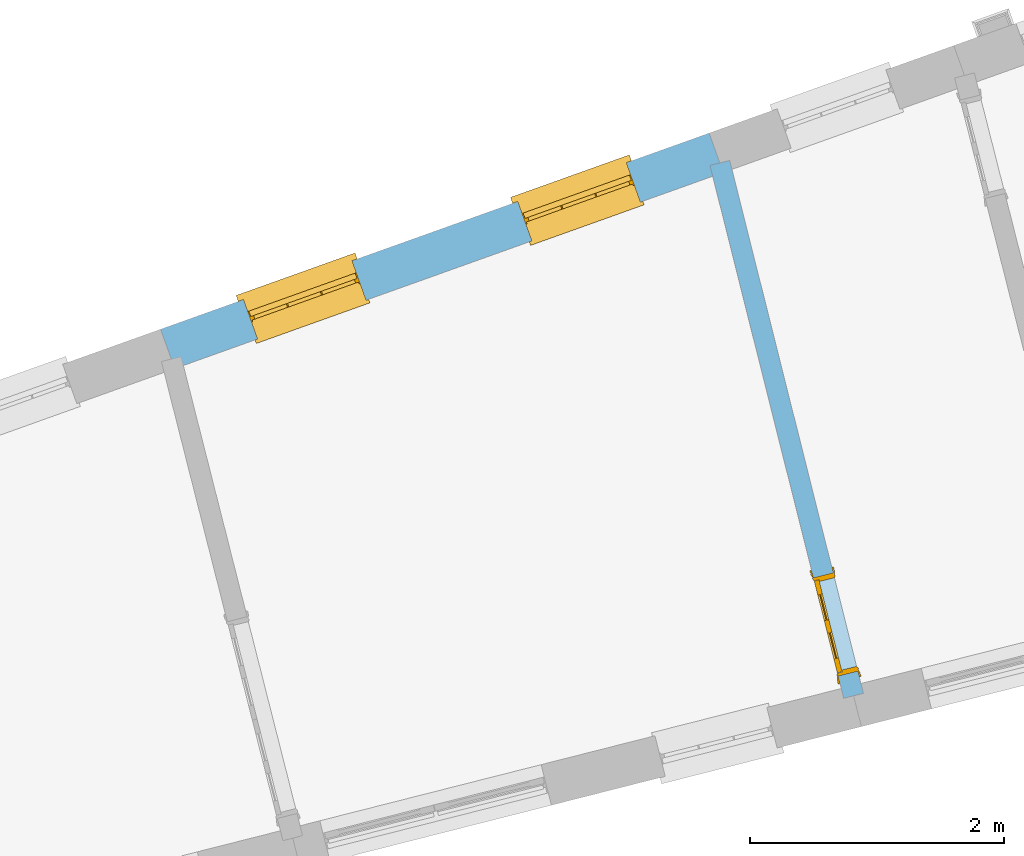
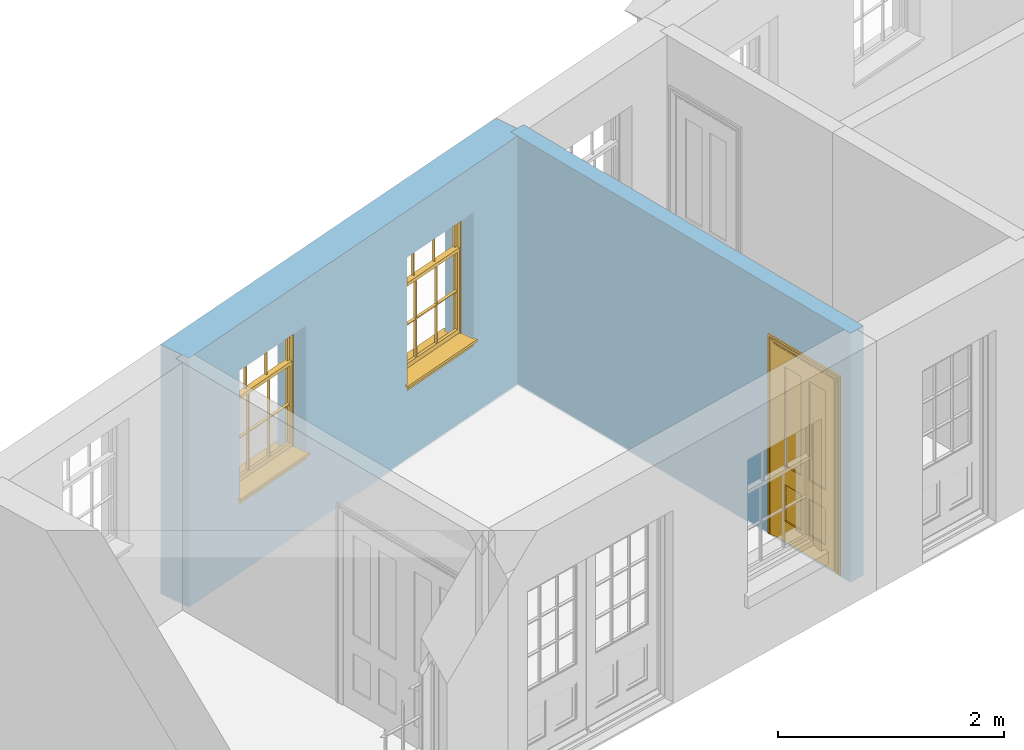
# One storey, part 6 of 15: 2 windows, 1 door, 3 openings, plus 2 elements that do not belong to this part.
"""IFC2X3 building model written with IfcOpenShell, lengths in metres."""

from ifc_helpers import new_model, si_unit, frame, origin, place, context, subcontext, project, spatial, polyline, outline, extrude, faceted_brep, material, layer, layer_set, layer_usage, element, fill, save


model = new_model("IFC2X3")

# Units and contexts
model_context = context("Model", 3, world=origin())
body_context = subcontext(model_context, "Body", "Model", "MODEL_VIEW")
ifc_project = project(units=[si_unit("PLANEANGLEUNIT", "RADIAN"), si_unit("MASSUNIT", "GRAM", prefix="KILO"), si_unit("FORCEUNIT", "NEWTON", prefix="KILO"), si_unit("LENGTHUNIT", "METRE")], contexts=[model_context])

# Site, building, storey
site_placement = place(None, origin())
site = spatial("IfcSite", under=ifc_project, at=site_placement, CompositionType="ELEMENT")
building_placement = place(None, origin())
building = spatial("IfcBuilding", under=site, at=building_placement, Name="Building plot-13", CompositionType="ELEMENT")
storey_placement = place(None, frame((0.0, 0.0, 4.0)))
storey = spatial("IfcBuildingStorey", under=building, at=storey_placement, Name="Floor 0", CompositionType="ELEMENT", Elevation=4.0)

# Wall, openings, windows
ifc_material_1 = material(Name="Masonry")
ifc_layer_1 = layer(ifc_material_1, 0.33, ventilated=False)
ifc_layer_set_1 = layer_set([ifc_layer_1], Name="My Wall")
ifc_layer_usage_1 = layer_usage(ifc_layer_set_1, "AXIS2", "NEGATIVE", 0.08)
wall_1_placement = place(storey_placement, origin())
wall_1 = element("IfcWallStandardCase", 1, at=wall_1_placement, inside=storey, material=ifc_layer_usage_1, Name="exterior", context=body_context, shape_type="SweptSolid", body=[
    extrude(outline(polyline([(70.16219482777, 49.0618716141414), (70.0510857180657, 49.3726042415572), (65.7269624100281, 47.8264212899844), (65.8380715197324, 47.5156886625686), (70.16219482777, 49.0618716141414)])), origin(), (0.0, 0.0, 1.0), 2.7),
])
opening_1_placement = place(storey_placement, frame((0.0, 0.0, 0.75)))
opening_1 = element("IfcOpeningElement", 2, at=opening_1_placement, cuts=wall_1, Name="Opening", ObjectType="Opening", context=body_context, shape_type="SweptSolid", body=[
    extrude(outline(polyline([(69.3984892712811, 49.1392543973472), (68.5416205108315, 48.8328626099808), (68.6527296205358, 48.522129982565), (69.5095983809854, 48.8285217699314), (69.3984892712811, 49.1392543973472)])), origin(), (0.0, 0.0, 1.0), 1.445),
])
opening_2_placement = place(storey_placement, frame((0.0, 0.0, 0.75)))
opening_2 = element("IfcOpeningElement", 3, at=opening_2_placement, cuts=wall_1, Name="Opening", ObjectType="Opening", context=body_context, shape_type="SweptSolid", body=[
    extrude(outline(polyline([(67.2364276172623, 48.3661629215608), (66.3795588568127, 48.0597711341944), (66.490667966517, 47.7490385067786), (67.3475367269666, 48.055430294145), (67.2364276172623, 48.3661629215608)])), origin(), (0.0, 0.0, 1.0), 1.445),
])
window_1_placement = place(storey_placement, frame((69.4826628392389, 48.9038508917292, 0.75), z_axis=(0.0, 0.0, 1.0), x_axis=(-0.856868760449572, -0.306391787366422, 0.0)))
window_1 = element("IfcWindow", 4, at=window_1_placement, inside=storey, Name="living street window", OverallHeight=1.445, OverallWidth=0.91, context=body_context, shape_type="Brep", held_by="IfcProductRepresentation", body=[
    faceted_brep([(0.876875, -0.105, 0.999097), (0.876875, -0.105, 1.411875), (0.9, -0.105, 1.435), (0.033125, -0.105, 1.411875), (0.033125, -0.105, 0.999097), (0.01, -0.105, 1.435), (0.033125, -0.135, 1.411875), (0.01, -0.135, 1.435), (0.033125, -0.135, 0.999097), (0.876875, -0.135, 1.411875), (0.876875, -0.135, 0.999097), (0.9, -0.135, 1.435), (0.033125, -0.105, 0.960972), (0.01, -0.105, 0.960972), (0.033125, -0.105, 0.548195), (0.876875, -0.105, 0.960972), (0.876875, -0.105, 0.548195), (0.9, -0.105, 0.960972), (0.876875, -0.105, 0.538195), (0.876875, -0.105, 0.125417), (0.9, -0.105, 0.077167), (0.033125, -0.105, 0.125417), (0.033125, -0.105, 0.538195), (0.01, -0.105, 0.077167), (0.9, -0.135, 0.960972), (0.01, -0.135, 0.960972), (-0.0425, -0.25, 0.01), (-0.0425, -0.3, 0.001667), (0.0, -0.25, 0.01), (0.9525, -0.25, 0.01), (0.91, -0.25, 0.01), (0.9525, -0.3, 0.001667), (-0.02, 0.08, 0.077167), (0.0, 0.08, 0.077167), (-0.02, 0.11, 0.077167), (0.0, -0.06, 0.077167), (0.01, -0.06, 0.077167), (0.91, -0.06, 0.077167), (0.91, 0.08, 0.077167), (0.9, -0.06, 0.077167), (0.93, 0.08, 0.077167), (0.93, 0.11, 0.077167), (0.01, -0.105, 0.999097), (0.01, -0.075, 0.999097), (0.9, -0.105, 0.999097), (0.9, -0.075, 0.999097), (0.876875, -0.075, 0.125417), (0.876875, -0.075, 0.538195), (0.9, -0.075, 0.077167), (0.876875, -0.075, 0.548195), (0.876875, -0.075, 0.960972), (0.033125, -0.075, 0.125417), (0.01, -0.075, 0.077167), (0.033125, -0.075, 0.538195), (0.033125, -0.075, 0.960972), (0.033125, -0.075, 0.548195), (-0.02, 0.08, 0.052167), (-0.02, 0.11, 0.052167), (0.93, 0.11, 0.052167), (0.93, 0.08, 0.052167), (0.91, 0.08, 0.052167), (0.0, 0.08, 0.052167), (0.91, -0.15, 0.026667), (0.0, -0.15, 0.026667), (-0.0425, -0.3, -0.123333), (0.9525, -0.3, -0.123333), (-0.0425, -0.25, -0.123333), (0.9525, -0.25, -0.123333), (0.01, -0.06, 1.435), (0.9, -0.06, 1.435), (0.0, -0.06, 1.445), (0.91, -0.06, 1.445), (0.01, -0.15, 0.077167), (0.9, -0.15, 0.077167), (0.592292, -0.105, 0.125417), (0.592292, -0.075, 0.125417), (0.317708, -0.075, 0.125417), (0.317708, -0.105, 0.125417), (0.592292, -0.105, 0.548195), (0.317708, -0.105, 0.548195), (0.317708, -0.105, 0.538195), (0.592292, -0.105, 0.538195), (0.592292, -0.075, 0.548195), (0.317708, -0.075, 0.548195), (0.602292, -0.075, 0.548195), (0.602292, -0.105, 0.548195), (0.317708, -0.075, 0.538195), (0.307708, -0.075, 0.125417), (0.307708, -0.075, 0.538195), (0.602292, -0.075, 0.538195), (0.602292, -0.075, 0.125417), (0.592292, -0.075, 0.538195), (0.307708, -0.075, 0.548195), (0.317708, -0.075, 0.960972), (0.307708, -0.075, 0.960972), (0.602292, -0.075, 0.960972), (0.592292, -0.075, 0.960972), (0.307708, -0.105, 0.538195), (0.307708, -0.105, 0.125417), (0.307708, -0.105, 0.548195), (0.307708, -0.105, 0.960972), (0.592292, -0.105, 0.960972), (0.317708, -0.105, 0.960972), (0.602292, -0.105, 0.960972), (0.602292, -0.105, 0.538195), (0.602292, -0.105, 0.125417), (0.317708, -0.135, 1.411875), (0.307708, -0.135, 1.411875), (0.307708, -0.135, 0.999097), (0.317708, -0.135, 0.999097), (0.602292, -0.135, 1.411875), (0.592292, -0.135, 1.411875), (0.592292, -0.135, 0.999097), (0.602292, -0.135, 0.999097), (0.317708, -0.105, 0.999097), (0.307708, -0.105, 0.999097), (0.307708, -0.105, 1.411875), (0.317708, -0.105, 1.411875), (0.602292, -0.105, 0.999097), (0.592292, -0.105, 0.999097), (0.592292, -0.105, 1.411875), (0.602292, -0.105, 1.411875), (0.91, -0.15, 1.445), (0.9, -0.15, 1.435), (0.01, -0.15, 1.435), (0.0, -0.15, 1.445), (0.91, -0.25, 0.0), (0.0, -0.25, 0.0), (0.91, 0.08, 0.0), (0.0, 0.08, 0.0)], [[[0, 1, 2]], [[3, 4, 5]], [[6, 7, 8]], [[9, 10, 11]], [[12, 13, 14]], [[15, 16, 17]], [[18, 19, 20]], [[21, 22, 23]], [[24, 15, 17]], [[13, 12, 25]], [[26, 27, 28]], [[29, 30, 31]], [[32, 33, 34]], [[35, 36, 33]], [[37, 38, 39]], [[40, 41, 38]], [[42, 4, 43]], [[44, 45, 0]], [[46, 47, 48]], [[49, 50, 45]], [[51, 52, 53]], [[54, 55, 43]], [[38, 33, 36, 39]], [[41, 34, 33, 38]], [[56, 32, 34, 57]], [[57, 34, 41, 58]], [[58, 41, 40, 59]], [[57, 58, 60, 61]], [[52, 48, 39, 36]], [[62, 63, 28, 30]], [[27, 31, 30, 28]], [[27, 64, 65, 31]], [[66, 67, 65, 64]], [[2, 5, 68, 69]], [[68, 70, 71, 69]], [[20, 23, 72, 73]], [[73, 72, 63, 62]], [[74, 75, 76, 77]], [[78, 79, 80, 81]], [[78, 82, 83, 79]], [[16, 49, 84, 85]], [[86, 76, 87, 88]], [[89, 90, 75, 91]], [[92, 88, 53, 55]], [[82, 91, 86, 83]], [[93, 83, 92, 94]], [[95, 84, 82, 96]], [[89, 84, 49, 47]], [[97, 88, 87, 98]], [[22, 53, 88, 97]], [[81, 91, 75, 74]], [[80, 86, 91, 81]], [[77, 76, 86, 80]], [[99, 92, 55, 14]], [[100, 94, 92, 99]], [[101, 96, 82, 78]], [[79, 83, 93, 102]], [[85, 84, 95, 103]], [[104, 89, 47, 18]], [[105, 90, 89, 104]], [[104, 18, 16, 85]], [[80, 97, 98, 77]], [[104, 81, 74, 105]], [[103, 101, 78, 85]], [[99, 14, 22, 97]], [[102, 100, 99, 79]], [[106, 107, 108, 109]], [[110, 111, 112, 113]], [[114, 115, 116, 117]], [[118, 119, 120, 121]], [[107, 116, 115, 108]], [[111, 120, 119, 112]], [[109, 114, 117, 106]], [[113, 118, 121, 110]], [[85, 78, 81, 104]], [[84, 89, 91, 82]], [[83, 86, 88, 92]], [[79, 99, 97, 80]], [[109, 112, 119, 114]], [[102, 93, 96, 101]], [[106, 117, 120, 111]], [[98, 87, 51, 21]], [[6, 3, 116, 107]], [[110, 121, 1, 9]], [[19, 46, 90, 105]], [[26, 66, 64, 27]], [[29, 31, 65, 67]], [[25, 24, 112, 109]], [[11, 7, 106, 111]], [[75, 48, 52, 76]], [[43, 45, 96, 93]], [[45, 43, 114, 119]], [[5, 2, 120, 117]], [[24, 25, 102, 101]], [[42, 5, 4]], [[2, 44, 0]], [[49, 45, 48, 47]], [[52, 43, 55, 53]], [[14, 13, 23, 22]], [[20, 17, 16, 18]], [[24, 11, 10]], [[25, 8, 7]], [[8, 4, 3, 6]], [[9, 1, 0, 10]], [[15, 50, 49, 16]], [[18, 47, 46, 19]], [[21, 51, 53, 22]], [[14, 55, 54, 12]], [[44, 2, 69, 45]], [[68, 5, 42, 43]], [[36, 35, 70, 68]], [[39, 69, 71, 37]], [[62, 122, 123, 73]], [[63, 72, 124, 125]], [[8, 108, 115, 4]], [[113, 10, 0, 118]], [[94, 100, 12, 54]], [[17, 20, 73, 24]], [[72, 23, 13, 25]], [[52, 36, 68, 43]], [[69, 39, 48, 45]], [[11, 24, 73, 123]], [[7, 124, 72, 25]], [[23, 77, 98]], [[98, 21, 23]], [[105, 74, 20]], [[20, 19, 105]], [[20, 74, 77, 23]], [[113, 112, 24]], [[24, 10, 113]], [[25, 109, 108]], [[108, 8, 25]], [[110, 9, 11]], [[11, 111, 110]], [[7, 6, 107]], [[107, 106, 7]], [[5, 117, 116]], [[116, 3, 5]], [[121, 120, 2]], [[2, 1, 121]], [[11, 123, 124, 7]], [[122, 125, 124, 123]], [[43, 93, 94]], [[94, 54, 43]], [[96, 45, 95]], [[50, 95, 45]], [[15, 103, 95, 50]], [[48, 75, 90]], [[90, 46, 48]], [[87, 76, 52]], [[52, 51, 87]], [[103, 15, 24]], [[24, 101, 103]], [[100, 102, 25]], [[25, 12, 100]], [[115, 114, 43]], [[43, 4, 115]], [[118, 0, 45]], [[45, 119, 118]], [[71, 70, 125, 122]], [[70, 35, 63, 125]], [[122, 62, 37, 71]], [[126, 67, 66, 127]], [[60, 58, 59]], [[38, 60, 59, 40]], [[61, 56, 57]], [[32, 56, 61, 33]], [[61, 60, 128, 129]], [[62, 60, 38, 37]], [[126, 128, 60, 62]], [[33, 61, 63, 35]], [[61, 129, 127, 63]], [[128, 126, 127, 129]], [[28, 127, 66, 26]], [[63, 127, 28]], [[29, 67, 126, 30]], [[30, 126, 62]]]),
])
fill(opening_1, window_1)
window_2_placement = place(storey_placement, frame((67.3206011852201, 48.1307594159428, 0.75), z_axis=(0.0, 0.0, 1.0), x_axis=(-0.856868760449572, -0.306391787366422, 0.0)))
window_2 = element("IfcWindow", 5, at=window_2_placement, inside=storey, Name="living street window", OverallHeight=1.445, OverallWidth=0.91, context=body_context, shape_type="Brep", held_by="IfcProductRepresentation", body=[
    faceted_brep([(0.876875, -0.105, 0.999097), (0.876875, -0.105, 1.411875), (0.9, -0.105, 1.435), (0.033125, -0.105, 1.411875), (0.033125, -0.105, 0.999097), (0.01, -0.105, 1.435), (0.033125, -0.135, 1.411875), (0.01, -0.135, 1.435), (0.033125, -0.135, 0.999097), (0.876875, -0.135, 1.411875), (0.876875, -0.135, 0.999097), (0.9, -0.135, 1.435), (0.033125, -0.105, 0.960972), (0.01, -0.105, 0.960972), (0.033125, -0.105, 0.548195), (0.876875, -0.105, 0.960972), (0.876875, -0.105, 0.548195), (0.9, -0.105, 0.960972), (0.876875, -0.105, 0.538195), (0.876875, -0.105, 0.125417), (0.9, -0.105, 0.077167), (0.033125, -0.105, 0.125417), (0.033125, -0.105, 0.538195), (0.01, -0.105, 0.077167), (0.9, -0.135, 0.960972), (0.01, -0.135, 0.960972), (-0.0425, -0.25, 0.01), (-0.0425, -0.3, 0.001667), (0.0, -0.25, 0.01), (0.9525, -0.25, 0.01), (0.91, -0.25, 0.01), (0.9525, -0.3, 0.001667), (-0.02, 0.08, 0.077167), (0.0, 0.08, 0.077167), (-0.02, 0.11, 0.077167), (0.0, -0.06, 0.077167), (0.01, -0.06, 0.077167), (0.91, -0.06, 0.077167), (0.91, 0.08, 0.077167), (0.9, -0.06, 0.077167), (0.93, 0.08, 0.077167), (0.93, 0.11, 0.077167), (0.01, -0.105, 0.999097), (0.01, -0.075, 0.999097), (0.9, -0.105, 0.999097), (0.9, -0.075, 0.999097), (0.876875, -0.075, 0.125417), (0.876875, -0.075, 0.538195), (0.9, -0.075, 0.077167), (0.876875, -0.075, 0.548195), (0.876875, -0.075, 0.960972), (0.033125, -0.075, 0.125417), (0.01, -0.075, 0.077167), (0.033125, -0.075, 0.538195), (0.033125, -0.075, 0.960972), (0.033125, -0.075, 0.548195), (-0.02, 0.08, 0.052167), (-0.02, 0.11, 0.052167), (0.93, 0.11, 0.052167), (0.93, 0.08, 0.052167), (0.91, 0.08, 0.052167), (0.0, 0.08, 0.052167), (0.91, -0.15, 0.026667), (0.0, -0.15, 0.026667), (-0.0425, -0.3, -0.123333), (0.9525, -0.3, -0.123333), (-0.0425, -0.25, -0.123333), (0.9525, -0.25, -0.123333), (0.01, -0.06, 1.435), (0.9, -0.06, 1.435), (0.0, -0.06, 1.445), (0.91, -0.06, 1.445), (0.01, -0.15, 0.077167), (0.9, -0.15, 0.077167), (0.592292, -0.105, 0.125417), (0.592292, -0.075, 0.125417), (0.317708, -0.075, 0.125417), (0.317708, -0.105, 0.125417), (0.592292, -0.105, 0.548195), (0.317708, -0.105, 0.548195), (0.317708, -0.105, 0.538195), (0.592292, -0.105, 0.538195), (0.592292, -0.075, 0.548195), (0.317708, -0.075, 0.548195), (0.602292, -0.075, 0.548195), (0.602292, -0.105, 0.548195), (0.317708, -0.075, 0.538195), (0.307708, -0.075, 0.125417), (0.307708, -0.075, 0.538195), (0.602292, -0.075, 0.538195), (0.602292, -0.075, 0.125417), (0.592292, -0.075, 0.538195), (0.307708, -0.075, 0.548195), (0.317708, -0.075, 0.960972), (0.307708, -0.075, 0.960972), (0.602292, -0.075, 0.960972), (0.592292, -0.075, 0.960972), (0.307708, -0.105, 0.538195), (0.307708, -0.105, 0.125417), (0.307708, -0.105, 0.548195), (0.307708, -0.105, 0.960972), (0.592292, -0.105, 0.960972), (0.317708, -0.105, 0.960972), (0.602292, -0.105, 0.960972), (0.602292, -0.105, 0.538195), (0.602292, -0.105, 0.125417), (0.317708, -0.135, 1.411875), (0.307708, -0.135, 1.411875), (0.307708, -0.135, 0.999097), (0.317708, -0.135, 0.999097), (0.602292, -0.135, 1.411875), (0.592292, -0.135, 1.411875), (0.592292, -0.135, 0.999097), (0.602292, -0.135, 0.999097), (0.317708, -0.105, 0.999097), (0.307708, -0.105, 0.999097), (0.307708, -0.105, 1.411875), (0.317708, -0.105, 1.411875), (0.602292, -0.105, 0.999097), (0.592292, -0.105, 0.999097), (0.592292, -0.105, 1.411875), (0.602292, -0.105, 1.411875), (0.91, -0.15, 1.445), (0.9, -0.15, 1.435), (0.01, -0.15, 1.435), (0.0, -0.15, 1.445), (0.91, -0.25, 0.0), (0.0, -0.25, 0.0), (0.91, 0.08, 0.0), (0.0, 0.08, 0.0)], [[[0, 1, 2]], [[3, 4, 5]], [[6, 7, 8]], [[9, 10, 11]], [[12, 13, 14]], [[15, 16, 17]], [[18, 19, 20]], [[21, 22, 23]], [[24, 15, 17]], [[13, 12, 25]], [[26, 27, 28]], [[29, 30, 31]], [[32, 33, 34]], [[35, 36, 33]], [[37, 38, 39]], [[40, 41, 38]], [[42, 4, 43]], [[44, 45, 0]], [[46, 47, 48]], [[49, 50, 45]], [[51, 52, 53]], [[54, 55, 43]], [[38, 33, 36, 39]], [[41, 34, 33, 38]], [[56, 32, 34, 57]], [[57, 34, 41, 58]], [[58, 41, 40, 59]], [[57, 58, 60, 61]], [[52, 48, 39, 36]], [[62, 63, 28, 30]], [[27, 31, 30, 28]], [[27, 64, 65, 31]], [[66, 67, 65, 64]], [[2, 5, 68, 69]], [[68, 70, 71, 69]], [[20, 23, 72, 73]], [[73, 72, 63, 62]], [[74, 75, 76, 77]], [[78, 79, 80, 81]], [[78, 82, 83, 79]], [[16, 49, 84, 85]], [[86, 76, 87, 88]], [[89, 90, 75, 91]], [[92, 88, 53, 55]], [[82, 91, 86, 83]], [[93, 83, 92, 94]], [[95, 84, 82, 96]], [[89, 84, 49, 47]], [[97, 88, 87, 98]], [[22, 53, 88, 97]], [[81, 91, 75, 74]], [[80, 86, 91, 81]], [[77, 76, 86, 80]], [[99, 92, 55, 14]], [[100, 94, 92, 99]], [[101, 96, 82, 78]], [[79, 83, 93, 102]], [[85, 84, 95, 103]], [[104, 89, 47, 18]], [[105, 90, 89, 104]], [[104, 18, 16, 85]], [[80, 97, 98, 77]], [[104, 81, 74, 105]], [[103, 101, 78, 85]], [[99, 14, 22, 97]], [[102, 100, 99, 79]], [[106, 107, 108, 109]], [[110, 111, 112, 113]], [[114, 115, 116, 117]], [[118, 119, 120, 121]], [[107, 116, 115, 108]], [[111, 120, 119, 112]], [[109, 114, 117, 106]], [[113, 118, 121, 110]], [[85, 78, 81, 104]], [[84, 89, 91, 82]], [[83, 86, 88, 92]], [[79, 99, 97, 80]], [[109, 112, 119, 114]], [[102, 93, 96, 101]], [[106, 117, 120, 111]], [[98, 87, 51, 21]], [[6, 3, 116, 107]], [[110, 121, 1, 9]], [[19, 46, 90, 105]], [[26, 66, 64, 27]], [[29, 31, 65, 67]], [[25, 24, 112, 109]], [[11, 7, 106, 111]], [[75, 48, 52, 76]], [[43, 45, 96, 93]], [[45, 43, 114, 119]], [[5, 2, 120, 117]], [[24, 25, 102, 101]], [[42, 5, 4]], [[2, 44, 0]], [[49, 45, 48, 47]], [[52, 43, 55, 53]], [[14, 13, 23, 22]], [[20, 17, 16, 18]], [[24, 11, 10]], [[25, 8, 7]], [[8, 4, 3, 6]], [[9, 1, 0, 10]], [[15, 50, 49, 16]], [[18, 47, 46, 19]], [[21, 51, 53, 22]], [[14, 55, 54, 12]], [[44, 2, 69, 45]], [[68, 5, 42, 43]], [[36, 35, 70, 68]], [[39, 69, 71, 37]], [[62, 122, 123, 73]], [[63, 72, 124, 125]], [[8, 108, 115, 4]], [[113, 10, 0, 118]], [[94, 100, 12, 54]], [[17, 20, 73, 24]], [[72, 23, 13, 25]], [[52, 36, 68, 43]], [[69, 39, 48, 45]], [[11, 24, 73, 123]], [[7, 124, 72, 25]], [[23, 77, 98]], [[98, 21, 23]], [[105, 74, 20]], [[20, 19, 105]], [[20, 74, 77, 23]], [[113, 112, 24]], [[24, 10, 113]], [[25, 109, 108]], [[108, 8, 25]], [[110, 9, 11]], [[11, 111, 110]], [[7, 6, 107]], [[107, 106, 7]], [[5, 117, 116]], [[116, 3, 5]], [[121, 120, 2]], [[2, 1, 121]], [[11, 123, 124, 7]], [[122, 125, 124, 123]], [[43, 93, 94]], [[94, 54, 43]], [[96, 45, 95]], [[50, 95, 45]], [[15, 103, 95, 50]], [[48, 75, 90]], [[90, 46, 48]], [[87, 76, 52]], [[52, 51, 87]], [[103, 15, 24]], [[24, 101, 103]], [[100, 102, 25]], [[25, 12, 100]], [[115, 114, 43]], [[43, 4, 115]], [[118, 0, 45]], [[45, 119, 118]], [[71, 70, 125, 122]], [[70, 35, 63, 125]], [[122, 62, 37, 71]], [[126, 67, 66, 127]], [[60, 58, 59]], [[38, 60, 59, 40]], [[61, 56, 57]], [[32, 56, 61, 33]], [[61, 60, 128, 129]], [[62, 60, 38, 37]], [[126, 128, 60, 62]], [[33, 61, 63, 35]], [[61, 129, 127, 63]], [[128, 126, 127, 129]], [[28, 127, 66, 26]], [[63, 127, 28]], [[29, 67, 126, 30]], [[30, 126, 62]]]),
])
fill(opening_2, window_2)

# Wall, opening, door
ifc_material_2 = material(Name="Masonry")
ifc_layer_2 = layer(ifc_material_2, 0.16, ventilated=False)
ifc_layer_set_2 = layer_set([ifc_layer_2], Name="My Wall")
ifc_layer_usage_2 = layer_usage(ifc_layer_set_2, "AXIS2", "NEGATIVE", 0.08)
wall_2_placement = place(storey_placement, origin())
wall_2 = element("IfcWallStandardCase", 6, at=wall_2_placement, inside=storey, material=ifc_layer_usage_2, Name="interior", context=body_context, shape_type="SweptSolid", body=[
    extrude(outline(polyline([(71.1118456496785, 44.9167468150566), (71.267034186696, 44.9556893108468), (70.2128535545322, 49.1566719838343), (70.0576650175148, 49.1177294880441), (71.1118456496785, 44.9167468150566)])), origin(), (0.0, 0.0, 1.0), 2.7),
])
opening_3_placement = place(storey_placement, frame((0.0, 0.0, 0.0199999999999996)))
opening_3 = element("IfcOpeningElement", 7, at=opening_3_placement, cuts=wall_2, Name="Opening", ObjectType="Opening", context=body_context, shape_type="SweptSolid", body=[
    extrude(outline(polyline([(71.2232238789319, 45.1302764149915), (71.0285113999808, 45.9062191000789), (70.8733228629633, 45.8672766042887), (71.0680353419145, 45.0913339192013), (71.2232238789319, 45.1302764149915)])), origin(), (0.0, 0.0, 1.0), 2.1),
])
door_placement = place(storey_placement, frame((71.1456296104232, 45.1108051670964, 0.0199999999999996), z_axis=(0.0, 0.0, 1.0), x_axis=(-0.194712478951175, 0.775942685087436, 0.0)))
door = element("IfcDoor", 8, at=door_placement, inside=storey, Name="living inside door", OverallHeight=2.1, OverallWidth=0.8, context=body_context, shape_type="Brep", held_by="IfcProductRepresentation", body=[
    faceted_brep([(0.773, 0.08, 1.895), (0.66, 0.08, 1.895), (0.66, 0.08, 2.073), (0.773, 0.08, 2.073), (0.773, 0.08, 0.82), (0.66, 0.08, 0.82), (0.45, 0.08, 1.895), (0.45, 0.08, 2.073), (0.773, 0.08, 0.62), (0.66, 0.08, 0.62), (0.66, 0.065, 0.82), (0.66, 0.065, 1.895), (0.45, 0.065, 1.895), (0.35, 0.08, 1.895), (0.35, 0.08, 2.073), (0.773, 0.08, 0.225), (0.66, 0.08, 0.225), (0.45, 0.08, 0.62), (0.45, 0.08, 0.82), (0.45, 0.065, 0.82), (0.35, 0.08, 0.82), (0.14, 0.08, 2.073), (0.14, 0.08, 1.895), (0.773, 0.08, 0.0), (0.66, 0.08, 0.0), (0.66, 0.065, 0.225), (0.66, 0.065, 0.62), (0.45, 0.065, 0.62), (0.35, 0.08, 0.62), (0.35, 0.065, 0.82), (0.35, 0.065, 1.895), (0.14, 0.065, 1.895), (0.027, 0.08, 2.073), (0.027, 0.08, 1.895), (0.773, 0.042, 0.0), (0.66, 0.042, 0.0), (0.45, 0.08, 0.0), (0.45, 0.08, 0.225), (0.45, 0.065, 0.225), (0.35, 0.08, 0.225), (0.14, 0.08, 0.82), (0.14, 0.08, 0.62), (0.14, 0.065, 0.82), (0.027, 0.08, 0.82), (0.773, 0.042, 0.225), (0.66, 0.042, 0.225), (0.45, 0.042, 0.0), (0.35, 0.08, 0.0), (0.35, 0.065, 0.225), (0.35, 0.065, 0.62), (0.14, 0.065, 0.62), (0.027, 0.08, 0.62), (0.773, 0.042, 0.62), (0.66, 0.042, 0.62), (0.45, 0.042, 0.225), (0.35, 0.042, 0.0), (0.14, 0.08, 0.225), (0.14, 0.08, 0.0), (0.14, 0.065, 0.225), (0.027, 0.08, 0.225), (0.773, 0.042, 0.82), (0.66, 0.042, 0.82), (0.66, 0.057, 0.62), (0.66, 0.057, 0.225), (0.45, 0.057, 0.225), (0.35, 0.042, 0.225), (0.14, 0.042, 0.0), (0.027, 0.08, 0.0), (0.773, 0.042, 1.895), (0.66, 0.042, 1.895), (0.45, 0.042, 0.62), (0.45, 0.042, 0.82), (0.45, 0.057, 0.62), (0.35, 0.042, 0.62), (0.14, 0.042, 0.225), (0.027, 0.042, 0.0), (0.773, 0.042, 2.073), (0.66, 0.042, 2.073), (0.66, 0.057, 1.895), (0.66, 0.057, 0.82), (0.45, 0.057, 0.82), (0.35, 0.042, 0.82), (0.35, 0.057, 0.62), (0.35, 0.057, 0.225), (0.14, 0.057, 0.225), (0.027, 0.042, 0.225), (0.45, 0.042, 1.895), (0.45, 0.042, 2.073), (0.45, 0.057, 1.895), (0.35, 0.042, 1.895), (0.14, 0.042, 0.82), (0.14, 0.042, 0.62), (0.14, 0.057, 0.62), (0.027, 0.042, 0.62), (0.35, 0.042, 2.073), (0.35, 0.057, 1.895), (0.35, 0.057, 0.82), (0.14, 0.057, 0.82), (0.027, 0.042, 0.82), (0.14, 0.042, 2.073), (0.14, 0.042, 1.895), (0.14, 0.057, 1.895), (0.027, 0.042, 1.895), (0.027, 0.042, 2.073), (0.02, 0.085, 0.0), (0.005, 0.09, 0.0), (0.005, 0.09, 2.095), (0.02, 0.085, 2.08), (0.02, 0.08, 0.0), (0.0, 0.085, 0.0), (0.0, 0.085, 2.1), (0.795, 0.09, 2.095), (0.78, 0.085, 2.08), (0.02, 0.08, 2.08), (0.0, 0.08, 0.0), (-0.032, 0.095, 0.0), (-0.032, 0.095, 2.132), (0.8, 0.085, 2.1), (0.795, 0.09, 0.0), (0.78, 0.085, 0.0), (0.78, 0.08, 2.08), (0.04, 0.04, 0.0), (0.025, 0.04, 0.0), (0.025, 0.04, 2.075), (0.04, 0.04, 2.06), (-0.04, 0.09, 0.0), (-0.04, 0.09, 2.14), (0.832, 0.095, 2.132), (0.8, 0.085, 0.0), (0.78, 0.08, 0.0), (0.8, 0.08, 0.0), (0.86, 0.08, 0.0), (0.86, 0.08, 2.16), (0.8, 0.08, 2.1), (-0.06, 0.08, 2.16), (0.0, 0.08, 2.1), (-0.06, 0.08, 0.0), (-0.04, 0.095, 0.0), (-0.04, 0.095, 2.14), (0.84, 0.09, 2.14), (0.832, 0.095, 0.0), (0.84, 0.09, 0.0), (0.86, 0.095, 0.0), (0.86, 0.095, 2.16), (-0.06, 0.095, 2.16), (-0.06, 0.095, 0.0), (0.84, 0.095, 0.0), (0.84, 0.095, 2.14), (-0.025, -0.095, 0.0), (-0.025, -0.09, 0.0), (-0.025, -0.09, 2.125), (-0.025, -0.095, 2.125), (-0.017, -0.095, 0.0), (-0.017, -0.095, 2.117), (0.825, -0.09, 2.125), (0.825, -0.095, 2.125), (0.825, -0.095, 0.0), (0.845, -0.095, 0.0), (-0.045, -0.095, 2.145), (-0.045, -0.095, 0.0), (0.845, -0.095, 2.145), (0.015, -0.085, 0.0), (0.015, -0.085, 2.085), (0.817, -0.095, 2.117), (0.825, -0.09, 0.0), (0.845, -0.08, 0.0), (0.845, -0.08, 2.145), (-0.045, -0.08, 2.145), (-0.045, -0.08, 0.0), (0.02, -0.09, 0.0), (0.02, -0.09, 2.08), (0.785, -0.085, 2.085), (0.817, -0.095, 0.0), (0.8, -0.08, 0.0), (0.8, -0.08, 2.1), (0.0, -0.08, 2.1), (0.0, -0.08, 0.0), (0.035, -0.085, 0.0), (0.035, -0.085, 2.065), (0.78, -0.09, 2.08), (0.785, -0.085, 0.0), (0.775, 0.04, 2.075), (0.76, 0.04, 2.06), (0.035, -0.08, 2.065), (0.035, -0.08, 0.0), (0.765, -0.085, 2.065), (0.78, -0.09, 0.0), (0.765, -0.08, 0.0), (0.765, -0.08, 2.065), (0.765, -0.085, 0.0), (0.04, -0.08, 2.06), (0.04, -0.08, 0.0), (0.76, -0.08, 2.06), (0.76, -0.08, 0.0), (0.76, 0.04, 0.0), (0.775, 0.04, 0.0), (0.025, 0.08, 0.0), (0.025, 0.08, 2.075), (0.775, 0.08, 0.0), (0.775, 0.08, 2.075)], [[[0, 1, 2, 3]], [[1, 0, 4, 5]], [[1, 6, 7, 2]], [[8, 9, 5, 4]], [[1, 5, 10, 11]], [[6, 1, 11, 12]], [[6, 13, 14, 7]], [[15, 16, 9, 8]], [[9, 17, 18, 5]], [[5, 18, 19, 10]], [[10, 19, 12, 11]], [[18, 6, 12, 19]], [[18, 20, 13, 6]], [[21, 14, 13, 22]], [[23, 24, 16, 15]], [[9, 16, 25, 26]], [[17, 9, 26, 27]], [[17, 28, 20, 18]], [[13, 20, 29, 30]], [[22, 13, 30, 31]], [[32, 21, 22, 33]], [[34, 35, 24, 23]], [[24, 36, 37, 16]], [[16, 37, 38, 25]], [[25, 38, 27, 26]], [[37, 17, 27, 38]], [[37, 39, 28, 17]], [[40, 20, 28, 41]], [[20, 40, 42, 29]], [[31, 30, 29, 42]], [[40, 22, 31, 42]], [[33, 22, 40, 43]], [[35, 34, 44, 45]], [[35, 46, 36, 24]], [[36, 47, 39, 37]], [[28, 39, 48, 49]], [[41, 28, 49, 50]], [[43, 40, 41, 51]], [[45, 44, 52, 53]], [[46, 35, 45, 54]], [[46, 55, 47, 36]], [[56, 39, 47, 57]], [[39, 56, 58, 48]], [[50, 49, 48, 58]], [[56, 41, 50, 58]], [[51, 41, 56, 59]], [[53, 52, 60, 61]], [[45, 53, 62, 63]], [[54, 45, 63, 64]], [[55, 46, 54, 65]], [[55, 66, 57, 47]], [[59, 56, 57, 67]], [[61, 60, 68, 69]], [[70, 53, 61, 71]], [[53, 70, 72, 62]], [[72, 64, 63, 62]], [[70, 54, 64, 72]], [[65, 54, 70, 73]], [[65, 74, 66, 55]], [[67, 57, 66, 75]], [[69, 68, 76, 77]], [[61, 69, 78, 79]], [[71, 61, 79, 80]], [[73, 70, 71, 81]], [[65, 73, 82, 83]], [[74, 65, 83, 84]], [[74, 85, 75, 66]], [[86, 69, 77, 87]], [[69, 86, 88, 78]], [[88, 80, 79, 78]], [[86, 71, 80, 88]], [[81, 71, 86, 89]], [[73, 81, 90, 91]], [[73, 91, 92, 82]], [[83, 82, 92, 84]], [[91, 74, 84, 92]], [[91, 93, 85, 74]], [[89, 86, 87, 94]], [[81, 89, 95, 96]], [[90, 81, 96, 97]], [[90, 98, 93, 91]], [[94, 99, 100, 89]], [[89, 100, 101, 95]], [[101, 97, 96, 95]], [[100, 90, 97, 101]], [[100, 102, 98, 90]], [[99, 103, 102, 100]], [[32, 103, 99, 21]], [[102, 103, 32, 33]], [[98, 102, 33, 43]], [[21, 99, 94, 14]], [[94, 87, 7, 14]], [[7, 87, 77, 2]], [[76, 3, 2, 77]], [[43, 51, 93, 98]], [[51, 59, 85, 93]], [[67, 75, 85, 59]], [[34, 23, 15, 44]], [[44, 15, 8, 52]], [[52, 8, 4, 60]], [[0, 68, 60, 4]], [[0, 3, 76, 68]], [[104, 105, 106, 107]], [[104, 108, 109, 105]], [[105, 109, 110, 106]], [[107, 106, 111, 112]], [[107, 113, 108, 104]], [[114, 109, 108]], [[109, 115, 116, 110]], [[106, 110, 117, 111]], [[112, 111, 118, 119]], [[113, 107, 112, 120]], [[121, 122, 123, 124]], [[115, 109, 114, 125]], [[115, 125, 126, 116]], [[110, 116, 127, 117]], [[111, 117, 128, 118]], [[118, 128, 129, 119]], [[120, 112, 119, 129]], [[130, 129, 128]], [[130, 131, 132, 133]], [[133, 132, 134, 135]], [[135, 134, 136, 114]], [[136, 125, 114]], [[125, 137, 138, 126]], [[116, 126, 139, 127]], [[117, 127, 140, 128]], [[141, 130, 128, 140]], [[131, 130, 141]], [[131, 142, 143, 132]], [[132, 143, 144, 134]], [[134, 144, 145, 136]], [[137, 125, 136, 145]], [[143, 142, 146]], [[143, 146, 147]], [[137, 145, 144]], [[143, 147, 138]], [[138, 137, 144]], [[143, 138, 144]], [[126, 138, 147, 139]], [[127, 139, 141, 140]], [[142, 131, 141, 146]], [[139, 147, 146, 141]], [[148, 149, 150, 151]], [[149, 152, 153, 150]], [[151, 150, 154, 155]], [[155, 156, 157]], [[158, 159, 148]], [[158, 148, 151]], [[155, 157, 160]], [[158, 151, 155]], [[155, 160, 158]], [[152, 161, 162, 153]], [[150, 153, 163, 154]], [[155, 154, 164, 156]], [[156, 164, 165, 157]], [[157, 165, 166, 160]], [[160, 166, 167, 158]], [[158, 167, 168, 159]], [[161, 169, 170, 162]], [[153, 162, 171, 163]], [[154, 163, 172, 164]], [[165, 164, 173]], [[165, 173, 174, 166]], [[166, 174, 175, 167]], [[167, 175, 176, 168]], [[169, 177, 178, 170]], [[162, 170, 179, 171]], [[163, 171, 180, 172]], [[172, 180, 173, 164]], [[124, 123, 181, 182]], [[183, 178, 177, 184]], [[170, 178, 185, 179]], [[171, 179, 186, 180]], [[187, 173, 180]], [[185, 188, 187, 189]], [[188, 185, 178, 183]], [[179, 185, 189, 186]], [[189, 187, 180, 186]], [[190, 183, 184, 191]], [[192, 188, 183, 190]], [[191, 184, 122, 121]], [[124, 190, 191, 121]], [[193, 187, 188, 192]], [[182, 192, 190, 124]], [[184, 176, 122]], [[194, 195, 187, 193]], [[192, 182, 194, 193]], [[161, 176, 184]], [[114, 108, 122, 176]], [[173, 187, 195]], [[152, 149, 176, 161]], [[169, 161, 184, 177]], [[196, 122, 108]], [[176, 175, 135, 114]], [[173, 195, 129, 130]], [[176, 149, 168]], [[123, 122, 196, 197]], [[196, 108, 113, 197]], [[175, 174, 133, 135]], [[198, 129, 195]], [[133, 174, 173, 130]], [[159, 168, 149, 148]], [[181, 123, 197, 199]], [[197, 113, 120, 199]], [[199, 120, 129, 198]], [[195, 181, 199, 198]], [[195, 194, 182, 181]]]),
])
fill(opening_3, door)

save(model, "model.ifc")
